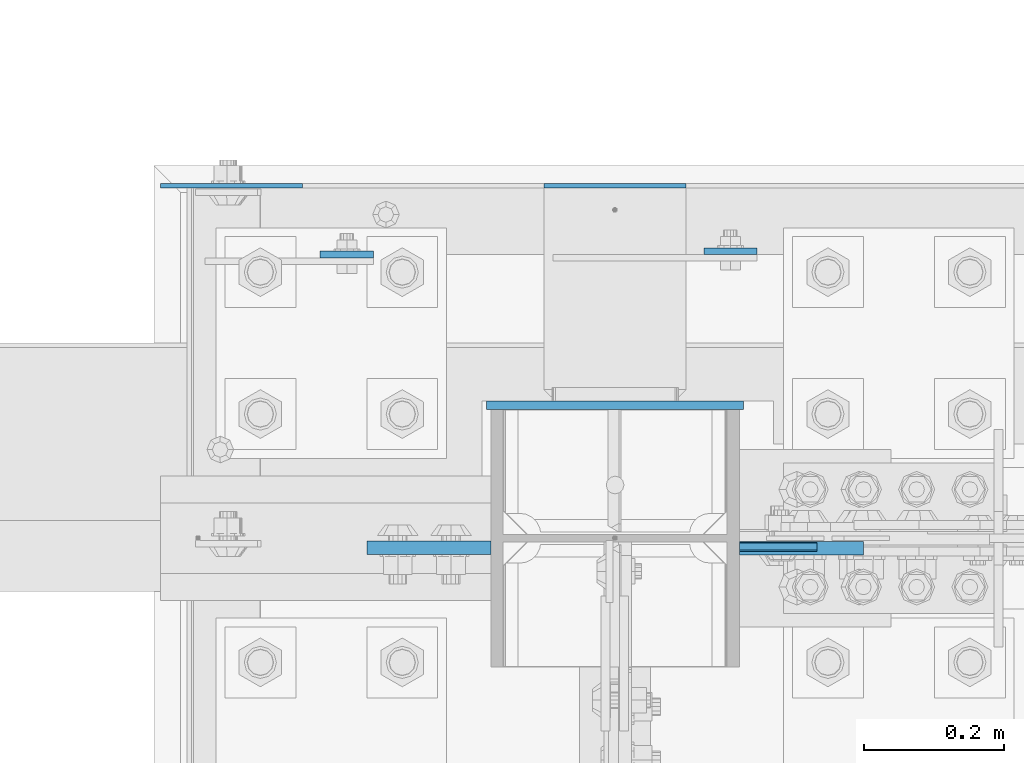
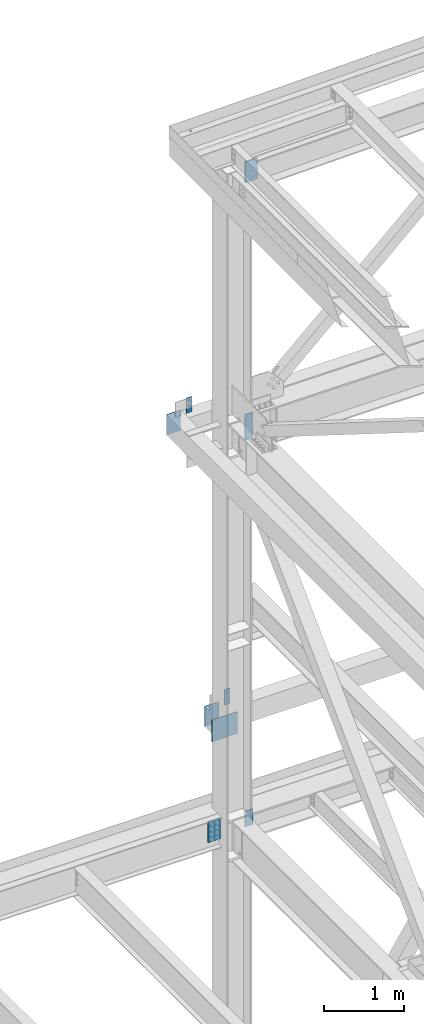
# One storey, part 1606 of 3843: 9 columns, 4 elements without a shape of their own.
"""IFC2X3 building model written with IfcOpenShell, lengths in millimetres."""

from ifc_helpers import new_model, si_unit, frame, origin_with_axes, place, context, subcontext, project, spatial, faceted_brep, material, type_object, element, aggregate, save


model = new_model("IFC2X3")

# Units and contexts
model_context = context("Model", 3, precision=1e-05, world=origin_with_axes())
body_context = subcontext(model_context, "Body", "Model", "MODEL_VIEW")
ifc_project = project(units=[si_unit("LENGTHUNIT", "METRE", prefix="MILLI"), si_unit("AREAUNIT", "SQUARE_METRE"), si_unit("VOLUMEUNIT", "CUBIC_METRE"), si_unit("MASSUNIT", "GRAM", prefix="KILO"), si_unit("TIMEUNIT", "SECOND"), si_unit("PLANEANGLEUNIT", "RADIAN"), si_unit("SOLIDANGLEUNIT", "STERADIAN"), si_unit("THERMODYNAMICTEMPERATUREUNIT", "DEGREE_CELSIUS"), si_unit("LUMINOUSINTENSITYUNIT", "LUMEN")], contexts=[model_context])

# Site, building, storey
site_placement = place(None, origin_with_axes())
site = spatial("IfcSite", under=ifc_project, at=site_placement, CompositionType="ELEMENT")
building_placement = place(site_placement, origin_with_axes())
building = spatial("IfcBuilding", under=site, at=building_placement, Name="Undefined", CompositionType="ELEMENT")
storey_placement = place(building_placement, origin_with_axes())
storey = spatial("IfcBuildingStorey", under=building, at=storey_placement, Name="Undefined", CompositionType="ELEMENT", Elevation=0.0)

# Assembly, column
assembly_1_placement = place(storey_placement, origin_with_axes())
assembly_1 = element("IfcElementAssembly", 1, at=assembly_1_placement, inside=storey, Name="GIRT", AssemblyPlace="NOTDEFINED", PredefinedType="RIGID_FRAME")
ifc_material = material(Name="STEEL/A572-50")
column_type_1 = type_object("IfcColumnType", PredefinedType="NOTDEFINED")
column_1_placement = place(assembly_1_placement, frame((76463.525, 105063.925, 42062.4), z_axis=(-1.0, 0.0, 0.0), x_axis=(0.0, 0.0, 1.0)))
column_1 = element("IfcColumn", 2, at=column_1_placement, type_object=column_type_1, material=ifc_material, Name="PLATE", context=body_context, shape_type="Brep", body=[
    faceted_brep([(0.0, 3.17499999999927, -101.600000000006), (0.0, 3.17499999999927, 101.600000000006), (304.800000000003, 3.17499999999927, 101.600000000006), (304.800000000003, 3.17499999999927, -101.600000000006), (0.0, -3.17499999999927, 101.600000000006), (304.800000000003, -3.17499999999927, 101.600000000006), (0.0, -3.17499999999927, -101.600000000006), (304.800000000003, -3.17499999999927, -101.600000000006)], [[[0, 1, 2, 3]], [[1, 4, 5, 2]], [[4, 6, 7, 5]], [[6, 0, 3, 7]], [[5, 7, 3, 2]], [[6, 4, 1, 0]]]),
])
aggregate(assembly_1, [column_1])

# Assembly, columns
assembly_2_placement = place(storey_placement, origin_with_axes())
assembly_2 = element("IfcElementAssembly", 3, at=assembly_2_placement, inside=storey, Name="COLUMN", AssemblyPlace="NOTDEFINED", PredefinedType="RIGID_FRAME")
column_2_placement = place(assembly_2_placement, frame((77012.8, 105063.925, 37439.6), z_axis=(-1.0, 0.0, 0.0), x_axis=(0.0, 0.0, 1.0)))
column_2 = element("IfcColumn", 4, at=column_2_placement, type_object=column_type_1, material=ifc_material, Name="PLATE", context=body_context, shape_type="Brep", body=[
    faceted_brep([(0.0, 3.17499999999927, -101.600000000006), (0.0, 3.17499999999927, 101.600000000006), (304.800000000003, 3.17499999999927, 101.600000000006), (304.800000000003, 3.17499999999927, -101.600000000006), (0.0, -3.17499999999927, 101.600000000006), (304.800000000003, -3.17499999999927, 101.600000000006), (0.0, -3.17499999999927, -101.600000000006), (304.800000000003, -3.17499999999927, -101.600000000006)], [[[0, 1, 2, 3]], [[1, 4, 5, 2]], [[4, 6, 7, 5]], [[6, 0, 3, 7]], [[5, 7, 3, 2]], [[6, 4, 1, 0]]]),
])
column_type_2 = type_object("IfcColumnType", PredefinedType="NOTDEFINED")
column_3_placement = place(assembly_2_placement, frame((77246.1625, 104546.4, 42000.4875), z_axis=(-1.0, 0.0, 0.0), x_axis=(0.0, 0.0, 1.0)))
column_3 = element("IfcColumn", 5, at=column_3_placement, type_object=column_type_2, material=ifc_material, Name="PLATE", context=body_context, shape_type="Brep", body=[
    faceted_brep([(0.0, 6.35000000000582, -55.5625), (0.0, 6.35000000000582, 55.5625), (393.699999999997, 6.35000000000582, 55.5625), (393.699999999997, 6.35000000000582, -55.5625), (0.0, -6.35000000000582, 55.5625), (393.699999999997, -6.35000000000582, 55.5625), (0.0, -6.35000000000582, -55.5625), (393.699999999997, -6.35000000000582, -55.5625)], [[[0, 1, 2, 3]], [[1, 4, 5, 2]], [[4, 6, 7, 5]], [[6, 0, 3, 7]], [[5, 7, 3, 2]], [[6, 4, 1, 0]]]),
])

# Assembly, column
assembly_3_placement = place(storey_placement, origin_with_axes())
assembly_3 = element("IfcElementAssembly", 6, at=assembly_3_placement, inside=storey, Name="GIRT", AssemblyPlace="NOTDEFINED", PredefinedType="RIGID_FRAME")
column_type_3 = type_object("IfcColumnType", PredefinedType="NOTDEFINED")
column_4_placement = place(assembly_3_placement, frame((77177.9, 104970.2625, 37744.4), z_axis=(-1.0, 0.0, 0.0), x_axis=(0.0, 0.0, 1.0)))
column_4 = element("IfcColumn", 7, at=column_4_placement, type_object=column_type_3, material=ifc_material, Name="PLATE", context=body_context, shape_type="Brep", body=[
    faceted_brep([(0.0, 4.76250000000073, -38.0999999999985), (0.0, 4.76250000000073, 38.0999999999985), (228.599999999999, 4.76249999999709, 38.1000000000058), (228.599999999999, 4.76249999999709, -38.1000000000058), (0.0, -4.76250000000073, 38.0999999999985), (228.599999999999, -4.76249999999709, 38.1000000000058), (0.0, -4.76250000000073, -38.0999999999985), (228.599999999999, -4.76249999999709, -38.1000000000058)], [[[0, 1, 2, 3]], [[1, 4, 5, 2]], [[4, 6, 7, 5]], [[6, 0, 3, 7]], [[5, 7, 3, 2]], [[6, 4, 1, 0]]]),
])
aggregate(assembly_3, [column_4])

assembly_4_placement = place(storey_placement, origin_with_axes())
assembly_4 = element("IfcElementAssembly", 8, at=assembly_4_placement, inside=storey, Name="GIRT", AssemblyPlace="NOTDEFINED", PredefinedType="RIGID_FRAME")
column_5_placement = place(assembly_4_placement, frame((76628.625, 104965.4995, 42367.2), z_axis=(-1.0, 0.0, 0.0), x_axis=(0.0, 0.0, 1.0)))
column_5 = element("IfcColumn", 9, at=column_5_placement, type_object=column_type_3, material=ifc_material, Name="PLATE", context=body_context, shape_type="Brep", body=[
    faceted_brep([(0.0, 4.76250000000073, -38.0999999999985), (0.0, 4.76250000000073, 38.0999999999985), (228.599999999999, 4.76249999999709, 38.1000000000058), (228.599999999999, 4.76249999999709, -38.1000000000058), (0.0, -4.76250000000073, 38.0999999999985), (228.599999999999, -4.76249999999709, 38.1000000000058), (0.0, -4.76250000000073, -38.0999999999985), (228.599999999999, -4.76249999999709, -38.1000000000058)], [[[0, 1, 2, 3]], [[1, 4, 5, 2]], [[4, 6, 7, 5]], [[6, 0, 3, 7]], [[5, 7, 3, 2]], [[6, 4, 1, 0]]]),
])
aggregate(assembly_4, [column_5])

# Column
column_type_4 = type_object("IfcColumnType", PredefinedType="NOTDEFINED")
column_6_placement = place(assembly_2_placement, frame((77246.1625, 104547.19375, 36131.5), z_axis=(-1.0, 0.0, 0.0), x_axis=(0.0, 0.0, 1.0)))
column_6 = element("IfcColumn", 10, at=column_6_placement, type_object=column_type_4, material=ifc_material, Name="PLATE", context=body_context, shape_type="Brep", body=[
    faceted_brep([(0.0, 4.76249999999709, -55.5625), (0.0, 4.76249999999709, 55.5625), (241.300000000003, 4.76249999999709, 55.5625), (241.300000000003, 4.76249999999709, -55.5625), (0.0, -4.76249999999709, 55.5625), (241.300000000003, -4.76249999999709, 55.5625), (0.0, -4.76249999999709, -55.5625), (241.300000000003, -4.76249999999709, -55.5625)], [[[0, 1, 2, 3]], [[1, 4, 5, 2]], [[4, 6, 7, 5]], [[6, 0, 3, 7]], [[5, 7, 3, 2]], [[6, 4, 1, 0]]]),
])

column_type_5 = type_object("IfcColumnType", PredefinedType="NOTDEFINED")
column_7_placement = place(assembly_2_placement, frame((77279.500000001, 104544.8125, 45916.910377094), z_axis=(-1.0, 0.0, 0.0), x_axis=(0.0, 0.0, 1.0)))
column_7 = element("IfcColumn", 11, at=column_7_placement, type_object=column_type_5, material=ifc_material, Name="PLATE", context=body_context, shape_type="Brep", body=[
    faceted_brep([(0.0, 9.52500000000146, -88.9000000000015), (0.0, 9.52500000000146, 88.9000000000015), (317.5, 9.52500000000146, 88.9000000000015), (317.5, 9.52500000000146, -88.9000000000015), (0.0, -9.52500000000146, 88.9000000000015), (317.5, -9.52500000000146, 88.9000000000015), (0.0, -9.52500000000146, -88.9000000000015), (317.5, -9.52500000000146, -88.9000000000015)], [[[0, 1, 2, 3]], [[1, 4, 5, 2]], [[4, 6, 7, 5]], [[6, 0, 3, 7]], [[5, 7, 3, 2]], [[6, 4, 1, 0]]]),
])

column_8_placement = place(assembly_2_placement, frame((76746.1, 104545.60625, 36080.7), z_axis=(1.0, 0.0, 0.0), x_axis=(0.0, 0.0, 1.0)))
column_8 = element("IfcColumn", 12, at=column_8_placement, type_object=column_type_5, material=ifc_material, Name="PLATE", context=body_context, shape_type="Brep", body=[
    faceted_brep([(0.0, 9.52500000000146, -88.9000000000015), (0.0, 9.52500000000146, 88.9000000000015), (317.5, 9.52500000000146, 88.9000000000015), (317.5, 9.52500000000146, -88.9000000000015), (0.0, -9.52500000000146, 88.9000000000015), (317.5, -9.52500000000146, 88.9000000000015), (0.0, -9.52500000000146, -88.9000000000015), (317.5, -9.52500000000146, -88.9000000000015)], [[[0, 1, 2, 3]], [[1, 4, 5, 2]], [[4, 6, 7, 5]], [[6, 0, 3, 7]], [[5, 7, 3, 2]], [[6, 4, 1, 0]]]),
])

column_type_6 = type_object("IfcColumnType", PredefinedType="NOTDEFINED")
column_9_placement = place(assembly_2_placement, frame((77012.8, 104749.6, 37426.9), z_axis=(1.0, 0.0, 0.0), x_axis=(0.0, 0.0, 1.0)))
column_9 = element("IfcColumn", 13, at=column_9_placement, type_object=column_type_6, material=ifc_material, Name="PLATE", context=body_context, shape_type="Brep", body=[
    faceted_brep([(0.0, 6.35000000000582, -184.149999999994), (0.0, 6.35000000000582, 184.149999999994), (330.199999999997, 6.35000000000582, 184.149999999994), (330.199999999997, 6.35000000000582, -184.149999999994), (0.0, -6.35000000000582, 184.149999999994), (330.199999999997, -6.35000000000582, 184.149999999994), (0.0, -6.35000000000582, -184.149999999994), (330.199999999997, -6.35000000000582, -184.149999999994)], [[[0, 1, 2, 3]], [[1, 4, 5, 2]], [[4, 6, 7, 5]], [[6, 0, 3, 7]], [[5, 7, 3, 2]], [[6, 4, 1, 0]]]),
])

aggregate(assembly_2, [column_3, column_7, column_9, column_2, column_6, column_8])

save(model, "model.ifc")
